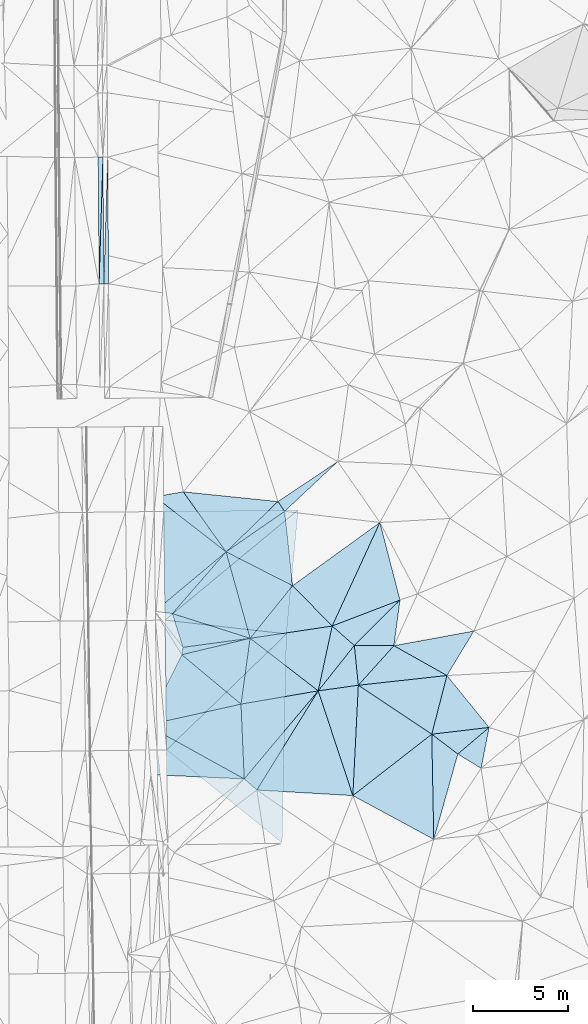
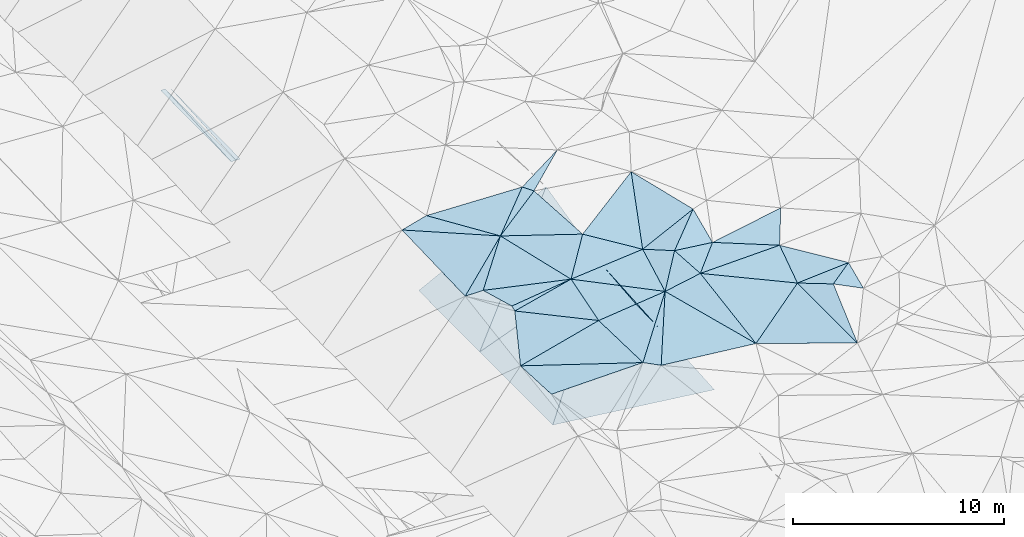
# One storey, part 38 of 275: 45 plates.
"""IFC2X3 building model written with IfcOpenShell, lengths in millimetres."""

import ifcopenshell
import ifcopenshell.guid

model = None  # the IFC model being written
_history = None  # IfcOwnerHistory: only IFC2X3 demands one
_inside = {}  # id of a spatial element -> (the spatial element, [elements in it])
_under = {}  # id of a project, library or spatial element -> (it, [spatial elements below it])
_declared = {}  # id of a project -> (the project, [libraries it declares])
_typed = {}  # id of a type object -> (the type object, [elements of that type])
_made_of = {}  # id of a material, layer set ... -> (it, [elements and type objects made of it])


def new_model(schema):
    """Start an empty IFC model of exactly this schema.

    Asked for "IFC4X3", IfcOpenShell would pick the latest addendum, in which some entities
    have other attributes; the version numbers below select the first issue.
    IFC2X3 requires an IfcOwnerHistory on every rooted entity: one is made here for all.
    """
    global model, _history
    if schema == "IFC4X3":
        model = ifcopenshell.file(schema_version=(4, 3, 0, 0))
    else:
        model = ifcopenshell.file(schema=schema)
    _inside.clear()
    _under.clear()
    _declared.clear()
    _typed.clear()
    _made_of.clear()
    _history = None
    if model.schema == "IFC2X3":
        org = make("IfcOrganization", Name="unknown")
        user = make(
            "IfcPersonAndOrganization",
            ThePerson=make("IfcPerson", FamilyName="unknown"),
            TheOrganization=org,
        )
        app = make(
            "IfcApplication",
            ApplicationDeveloper=org,
            Version="unknown",
            ApplicationFullName="unknown",
            ApplicationIdentifier="unknown",
        )
        _history = make(
            "IfcOwnerHistory",
            OwningUser=user,
            OwningApplication=app,
            ChangeAction="ADDED",
            CreationDate=0,
        )
    return model


def make(cls, **values):
    """One entity of the class cls with the attributes given. An attribute that is None is left unset."""
    return model.create_entity(
        cls, **{name: value for name, value in values.items() if value is not None}
    )


def rooted(cls, **values):
    """An entity with a GlobalId (a new one), such as an element, a storey or a relation."""
    return make(cls, GlobalId=ifcopenshell.guid.new(), OwnerHistory=_history, **values)


def si_unit(unit_type, name, prefix=None):
    """IfcSIUnit, for example si_unit("LENGTHUNIT", "METRE", prefix="MILLI")."""
    return make("IfcSIUnit", UnitType=unit_type, Prefix=prefix, Name=name)


def assignment(units):
    """IfcUnitAssignment: the units of a project."""
    return None if units is None else make("IfcUnitAssignment", Units=units)


def point(xyz):
    """IfcCartesianPoint."""
    return None if xyz is None else make("IfcCartesianPoint", Coordinates=xyz)


def direction(xyz):
    """IfcDirection."""
    return None if xyz is None else make("IfcDirection", DirectionRatios=xyz)


def frame(location, z_axis=None, x_axis=None):
    """IfcAxis2Placement3D, a coordinate frame: its origin and axes. An axis left out is left unset."""
    return make(
        "IfcAxis2Placement3D",
        Location=point(location),
        Axis=direction(z_axis),
        RefDirection=direction(x_axis),
    )


def origin_with_axes():
    """The frame at (0, 0, 0) with the z axis (0, 0, 1) and the x axis (1, 0, 0) written out."""
    return frame((0.0, 0.0, 0.0), z_axis=(0.0, 0.0, 1.0), x_axis=(1.0, 0.0, 0.0))


def place(relative_to, where):
    """IfcLocalPlacement: puts the frame where relative to a parent placement (None: the world)."""
    return make(
        "IfcLocalPlacement", PlacementRelTo=relative_to, RelativePlacement=where
    )


def context(
    kind, dimensions, precision=None, world=None, true_north=None, identifier=None
):
    """IfcGeometricRepresentationContext, for example the 3D "Model" context."""
    return make(
        "IfcGeometricRepresentationContext",
        ContextIdentifier=identifier,
        ContextType=kind,
        CoordinateSpaceDimension=dimensions,
        Precision=precision,
        WorldCoordinateSystem=world,
        TrueNorth=true_north,
    )


def subcontext(parent, identifier, kind, view, scale=None):
    """IfcGeometricRepresentationSubContext, for example "Body" below "Model"."""
    return make(
        "IfcGeometricRepresentationSubContext",
        ContextIdentifier=identifier,
        ContextType=kind,
        ParentContext=parent,
        TargetScale=scale,
        TargetView=view,
    )


def project(units=None, contexts=None):
    """IfcProject with its units and contexts."""
    return rooted(
        "IfcProject",
        Name="project",
        RepresentationContexts=contexts,
        UnitsInContext=assignment(units),
    )


def spatial(cls, under=None, at=None, **own):
    """A site, building, storey or space (cls), placed at a placement, below another one or the project."""
    s = rooted(cls, ObjectPlacement=at, **own)
    if under is not None:
        _under.setdefault(under.id(), (under, []))[1].append(s)
    return s


def polyline(points):
    """IfcPolyline through the points."""
    return make("IfcPolyline", Points=[point(p) for p in points])


def outline(outer, holes=None, kind="AREA"):
    """IfcArbitraryClosedProfileDef: a profile drawn as a closed curve; with holes, ...WithVoids."""
    if holes is None:
        return make("IfcArbitraryClosedProfileDef", ProfileType=kind, OuterCurve=outer)
    return make(
        "IfcArbitraryProfileDefWithVoids",
        ProfileType=kind,
        OuterCurve=outer,
        InnerCurves=holes,
    )


def extrude(swept, where, along, depth):
    """IfcExtrudedAreaSolid: the profile swept, set in the frame where, extruded along a direction by depth."""
    return make(
        "IfcExtrudedAreaSolid",
        SweptArea=swept,
        Position=where,
        ExtrudedDirection=direction(along),
        Depth=depth,
    )


def shape(context_of_items, identifier, shape_type, items):
    """IfcShapeRepresentation: the items that make up one representation, for example the "Body"."""
    return make(
        "IfcShapeRepresentation",
        ContextOfItems=context_of_items,
        RepresentationIdentifier=identifier,
        RepresentationType=shape_type,
        Items=items,
    )


def material(Name=None, Category=None):
    """IfcMaterial."""
    return make("IfcMaterial", Name=Name, Category=Category)


def made_of(thing, what):
    """Note that an element or type object is made of a material, layer set ...; save() writes the relation."""
    if what is not None:
        _made_of.setdefault(what.id(), (what, []))[1].append(thing)
    return thing


def type_object(cls, material=None, **own):
    """A type object (cls), such as IfcWallType, which elements share."""
    return made_of(rooted(cls, **own), material)


def element(
    cls,
    number,
    at=None,
    inside=None,
    cuts=None,
    type_object=None,
    material=None,
    context=None,
    identifier="Body",
    shape_type=None,
    held_by="IfcProductDefinitionShape",
    body=None,
    shapes=None,
    **own,
):
    """One element of the class cls, such as IfcWall. Its Tag is "e" and its number.

    at: its placement. inside: the storey or other place that contains it. cuts: it is an
    opening in that element (IfcRelVoidsElement). A single representation is given by context,
    identifier, shape_type and body (its items); several are given by shapes. held_by: the class
    of the entity that holds the representations. save() writes the other relations.
    """
    e = rooted(cls, Tag="e%d" % number, ObjectPlacement=at, **own)
    if body is not None:
        shapes = [shape(context, identifier, shape_type, body)]
    if shapes is not None:
        e.Representation = make(held_by, Representations=shapes)
    if inside is not None:
        _inside.setdefault(inside.id(), (inside, []))[1].append(e)
    if cuts is not None:
        rooted(
            "IfcRelVoidsElement", RelatingBuildingElement=cuts, RelatedOpeningElement=e
        )
    if type_object is not None:
        _typed.setdefault(type_object.id(), (type_object, []))[1].append(e)
    return made_of(e, material)


def aggregate(whole, parts):
    """IfcRelAggregates: a whole, such as a stair, and the parts it consists of."""
    return rooted("IfcRelAggregates", RelatingObject=whole, RelatedObjects=parts)


def save(model, path):
    """Write the relations noted so far, then the file.

    IfcRelAggregates (storeys below a building ...), IfcRelContainedInSpatialStructure (elements
    in a storey), IfcRelDefinesByType, IfcRelAssociatesMaterial and IfcRelDeclares: one each for
    every whole, place, type object, material and project.
    """
    for whole, parts in _under.values():
        aggregate(whole, parts)
    for where, things in _inside.values():
        rooted(
            "IfcRelContainedInSpatialStructure",
            RelatedElements=things,
            RelatingStructure=where,
        )
    for kind, things in _typed.values():
        rooted("IfcRelDefinesByType", RelatedObjects=things, RelatingType=kind)
    for what, things in _made_of.values():
        rooted("IfcRelAssociatesMaterial", RelatedObjects=things, RelatingMaterial=what)
    for by, libraries in _declared.values():
        rooted("IfcRelDeclares", RelatingContext=by, RelatedDefinitions=libraries)
    model.write(path)


model = new_model("IFC2X3")

# Units and contexts
model_context = context("Model", 3, precision=1e-05, world=origin_with_axes())
body_context = subcontext(model_context, "Body", "Model", "MODEL_VIEW")
ifc_project = project(units=[si_unit("LENGTHUNIT", "METRE", prefix="MILLI"), si_unit("AREAUNIT", "SQUARE_METRE"), si_unit("VOLUMEUNIT", "CUBIC_METRE"), si_unit("MASSUNIT", "GRAM", prefix="KILO"), si_unit("TIMEUNIT", "SECOND"), si_unit("PLANEANGLEUNIT", "RADIAN"), si_unit("SOLIDANGLEUNIT", "STERADIAN"), si_unit("THERMODYNAMICTEMPERATUREUNIT", "DEGREE_CELSIUS"), si_unit("LUMINOUSINTENSITYUNIT", "LUMEN")], contexts=[model_context])

# Site, building, storey
site_placement = place(None, origin_with_axes())
site = spatial("IfcSite", under=ifc_project, at=site_placement, CompositionType="ELEMENT")
building_placement = place(site_placement, origin_with_axes())
building = spatial("IfcBuilding", under=site, at=building_placement, Name="Undefined", CompositionType="ELEMENT")
storey_placement = place(building_placement, origin_with_axes())
storey = spatial("IfcBuildingStorey", under=building, at=storey_placement, Name="Undefined", CompositionType="ELEMENT", Elevation=0.0)

# Plates
ifc_material = material()
plate_type_1 = type_object("IfcPlateType", PredefinedType="NOTDEFINED")
plate_1_placement = place(storey_placement, frame((-54942.9915111261, 36382.3782715387, 42080.1552035688), z_axis=(0.0198445312572419, 0.0205778341009198, -0.999591290139573), x_axis=(0.0071782370249891, -0.999765334401105, -0.0204389100262064)))
element("IfcPlate", 1, at=plate_1_placement, inside=storey, type_object=plate_type_1, material=ifc_material, Name="00_PR", context=body_context, shape_type="SweptSolid", body=[
    extrude(outline(polyline([(0.0, 0.0), (6633.6708984375, -2.11002770811319e-10), (6633.7734375, 250.050033569336), (0.0, 0.0)])), frame((-8.85201319254618e-08, 2.18876761149539e-07, -0.5000001331573), z_axis=(0.0, 0.0, 1.0), x_axis=(1.0, 0.0, 0.0)), (0.0, 0.0, 1.0), 1.0),
])
plate_2_placement = place(storey_placement, frame((-54693.0324596577, 36384.1727438642, 42067.6557273088), z_axis=(-0.0500723807362352, 0.0200544303251957, -0.998544228620714), x_axis=(0.0071782370249891, -0.999765334401105, -0.0204389100262064)))
element("IfcPlate", 2, at=plate_2_placement, inside=storey, type_object=plate_type_1, material=ifc_material, Name="00_PR", context=body_context, shape_type="SweptSolid", body=[
    extrude(outline(polyline([(0.0, 0.0), (6633.6708984375, -2.11002770811319e-10), (6633.4150390625, 250.311706542969), (0.0, 0.0)])), frame((-8.85201319254618e-08, 2.18876761149539e-07, -0.5000001331573), z_axis=(0.0, 0.0, 1.0), x_axis=(1.0, 0.0, 0.0)), (0.0, 0.0, 1.0), 1.0),
])
plate_3_placement = place(storey_placement, frame((-55145.3670530772, 29748.4686331468, 41939.5702051205), z_axis=(0.0198445312572419, 0.0205778341009198, -0.999591290139573), x_axis=(-0.00717823700979567, 0.999765334400991, 0.0204389100371159)))
element("IfcPlate", 3, at=plate_3_placement, inside=storey, type_object=plate_type_1, material=ifc_material, Name="00_PR", context=body_context, shape_type="SweptSolid", body=[
    extrude(outline(polyline([(0.0, 0.0), (6633.671875, 2.05327523872256e-08), (6633.7734375, 250.049514770508), (0.0, 0.0)])), frame((-8.85201319254618e-08, 2.18876761149539e-07, -0.5000001331573), z_axis=(0.0, 0.0, 1.0), x_axis=(1.0, 0.0, 0.0)), (0.0, 0.0, 1.0), 1.0),
])
plate_type_2 = type_object("IfcPlateType", PredefinedType="NOTDEFINED")
plate_4_placement = place(storey_placement, frame((-45430.231883787, 17833.4559001937, 44079.5016784651), z_axis=(0.0278588885497635, 0.0772522264791411, -0.996622283431786), x_axis=(0.106934338629131, -0.991518355710877, -0.0738674320005101)))
element("IfcPlate", 4, at=plate_4_placement, inside=storey, type_object=plate_type_2, material=ifc_material, Name="00", context=body_context, shape_type="SweptSolid", body=[
    extrude(outline(polyline([(0.0, 0.0), (3925.9521484375, 1.47701939567924e-09), (1792.91540527344, 3276.21044921875), (0.0, 0.0)])), frame((-8.85201319254618e-08, 2.18876761149539e-07, -0.5000001331573), z_axis=(0.0, 0.0, 1.0), x_axis=(1.0, 0.0, 0.0)), (0.0, 0.0, 1.0), 1.0),
])
plate_type_3 = type_object("IfcPlateType", PredefinedType="NOTDEFINED")
plate_5_placement = place(storey_placement, frame((-39706.3607982611, 10796.9886034841, 43359.5010595208), z_axis=(-0.0651260608262008, 0.00556111429460332, -0.997861548617374), x_axis=(0.870385619377066, -0.488758669464644, -0.0595301319060548)))
element("IfcPlate", 5, at=plate_5_placement, inside=storey, type_object=plate_type_3, material=ifc_material, Name="00", context=body_context, shape_type="SweptSolid", body=[
    extrude(outline(polyline([(0.0, 0.0), (3191.66088867188, 9.51149559114128e-09), (-615.760864257813, 2717.37719726563), (0.0, 0.0)])), frame((-8.85201319254618e-08, 2.18876761149539e-07, -0.5000001331573), z_axis=(0.0, 0.0, 1.0), x_axis=(1.0, 0.0, 0.0)), (0.0, 0.0, 1.0), 1.0),
])
plate_type_4 = type_object("IfcPlateType", PredefinedType="NOTDEFINED")
plate_6_placement = place(storey_placement, frame((-44724.4771058375, 17903.7667722311, 44038.7318903429), z_axis=(0.446903759838823, 0.0251629956808119, -0.894228076661816), x_axis=(-0.0919898739759389, -0.993012730312049, -0.0739160369886005)))
element("IfcPlate", 6, at=plate_6_placement, inside=storey, type_object=plate_type_4, material=ifc_material, Name="00_PR", context=body_context, shape_type="SweptSolid", body=[
    extrude(outline(polyline([(0.0, 0.0), (6534.427734375, -7.82165443524718e-09), (6635.34326171875, 7143.662109375), (0.0, 0.0)])), frame((-8.85201319254618e-08, 2.18876761149539e-07, -0.5000001331573), z_axis=(0.0, 0.0, 1.0), x_axis=(1.0, 0.0, 0.0)), (0.0, 0.0, 1.0), 1.0),
])
plate_type_5 = type_object("IfcPlateType", PredefinedType="NOTDEFINED")
plate_7_placement = place(storey_placement, frame((-45325.5784005657, 11414.9969817729, 43555.7328380618), z_axis=(0.446680012940053, 0.0253921294447093, -0.89433338627278), x_axis=(-0.0212792639438346, -0.999012910810186, -0.0389922679587617)))
element("IfcPlate", 7, at=plate_7_placement, inside=storey, type_object=plate_type_5, material=ifc_material, Name="00_PR", context=body_context, shape_type="SweptSolid", body=[
    extrude(outline(polyline([(0.0, 0.0), (10952.9150390625, -5.12955011799932e-09), (6325.18896484375, 6871.359375), (0.0, 0.0)])), frame((-8.85201319254618e-08, 2.18876761149539e-07, -0.5000001331573), z_axis=(0.0, 0.0, 1.0), x_axis=(1.0, 0.0, 0.0)), (0.0, 0.0, 1.0), 1.0),
])
plate_type_6 = type_object("IfcPlateType", PredefinedType="NOTDEFINED")
plate_8_placement = place(storey_placement, frame((-51691.5765874755, 12138.4029524377, 40394.586883327), z_axis=(0.446872865494103, 0.0252092656988721, -0.894242212718687), x_axis=(-0.0115226870499545, 0.999682155734166, 0.022423540974605)))
element("IfcPlate", 8, at=plate_8_placement, inside=storey, type_object=plate_type_6, material=ifc_material, Name="00_PR", context=body_context, shape_type="SweptSolid", body=[
    extrude(outline(polyline([(0.0, 0.0), (5690.53759765625, -5.3114490583539e-10), (5764.96630859375, 7862.8779296875), (0.0, 0.0)])), frame((-8.85201319254618e-08, 2.18876761149539e-07, -0.5000001331573), z_axis=(0.0, 0.0, 1.0), x_axis=(1.0, 0.0, 0.0)), (0.0, 0.0, 1.0), 1.0),
])
plate_type_7 = type_object("IfcPlateType", PredefinedType="NOTDEFINED")
plate_9_placement = place(storey_placement, frame((-51606.1972889804, 5346.4973654503, 40246.5428887471), z_axis=(0.446899491070269, 0.0251095362468801, -0.894231712740384), x_axis=(-0.0125667630554567, 0.999683581198485, 0.0217902259850709)))
element("IfcPlate", 9, at=plate_9_placement, inside=storey, type_object=plate_type_7, material=ifc_material, Name="00_PR", context=body_context, shape_type="SweptSolid", body=[
    extrude(outline(polyline([(0.0, 0.0), (6794.05517578125, -5.5297277867794e-09), (6059.76025390625, 7106.53955078125), (0.0, 0.0)])), frame((-8.85201319254618e-08, 2.18876761149539e-07, -0.5000001331573), z_axis=(0.0, 0.0, 1.0), x_axis=(1.0, 0.0, 0.0)), (0.0, 0.0, 1.0), 1.0),
])
plate_type_8 = type_object("IfcPlateType", PredefinedType="NOTDEFINED")
plate_10_placement = place(storey_placement, frame((-41855.9755057168, 2947.52692122357, 43009.5021130421), z_axis=(0.050879424054759, 0.0767183679161113, -0.995753772893753), x_axis=(-0.313273531606973, 0.947949097745862, 0.0570280849871394)))
element("IfcPlate", 10, at=plate_10_placement, inside=storey, type_object=plate_type_8, material=ifc_material, Name="00", context=body_context, shape_type="SweptSolid", body=[
    extrude(outline(polyline([(0.0, 0.0), (5786.62255859375, 4.63478500023484e-09), (5415.1279296875, 2092.10229492188), (0.0, 0.0)])), frame((-8.85201319254618e-08, 2.18876761149539e-07, -0.5000001331573), z_axis=(0.0, 0.0, 1.0), x_axis=(1.0, 0.0, 0.0)), (0.0, 0.0, 1.0), 1.0),
])
plate_type_9 = type_object("IfcPlateType", PredefinedType="NOTDEFINED")
plate_11_placement = place(storey_placement, frame((-48494.6611058012, 15713.3185352938, 43829.5005989199), z_axis=(0.0127846669744032, 0.0476697506053442, -0.998781331006731), x_axis=(0.89124718195064, -0.453402439250082, -0.0102317519085897)))
element("IfcPlate", 11, at=plate_11_placement, inside=storey, type_object=plate_type_9, material=ifc_material, Name="00", context=body_context, shape_type="SweptSolid", body=[
    extrude(outline(polyline([(0.0, 0.0), (3909.39892578125, 3.64889274351299e-09), (3176.421875, 3469.18505859375), (0.0, 0.0)])), frame((-8.85201319254618e-08, 2.18876761149539e-07, -0.5000001331573), z_axis=(0.0, 0.0, 1.0), x_axis=(1.0, 0.0, 0.0)), (0.0, 0.0, 1.0), 1.0),
])
plate_type_10 = type_object("IfcPlateType", PredefinedType="NOTDEFINED")
plate_12_placement = place(storey_placement, frame((-36357.6802074656, 5126.7429942699, 43219.5032496987), z_axis=(-0.0131080272075688, -0.11314237284293, -0.993492316573308), x_axis=(-0.79525424323636, 0.603472943562298, -0.0582331091632559)))
element("IfcPlate", 12, at=plate_12_placement, inside=storey, type_object=plate_type_10, material=ifc_material, Name="00", context=body_context, shape_type="SweptSolid", body=[
    extrude(outline(polyline([(0.0, 0.0), (1717.23620605469, -4.3473846744746e-09), (-452.354797363281, 2107.95532226563), (0.0, 0.0)])), frame((-8.85201319254618e-08, 2.18876761149539e-07, -0.5000001331573), z_axis=(0.0, 0.0, 1.0), x_axis=(1.0, 0.0, 0.0)), (0.0, 0.0, 1.0), 1.0),
])
plate_type_11 = type_object("IfcPlateType", PredefinedType="NOTDEFINED")
plate_13_placement = place(storey_placement, frame((-45430.2877897706, 17833.4276903817, 44079.5018639715), z_axis=(-0.0839553284117798, 0.0208324255081803, -0.996251731681665), x_axis=(-0.559073778349548, 0.826613140354134, 0.0643989639345107)))
element("IfcPlate", 13, at=plate_13_placement, inside=storey, type_object=plate_type_11, material=ifc_material, Name="00", context=body_context, shape_type="SweptSolid", body=[
    extrude(outline(polyline([(0.0, 0.0), (621.127990722656, 8.94942786544561e-10), (588.284545898438, 3772.78686523438), (0.0, 0.0)])), frame((-8.85201319254618e-08, 2.18876761149539e-07, -0.5000001331573), z_axis=(0.0, 0.0, 1.0), x_axis=(1.0, 0.0, 0.0)), (0.0, 0.0, 1.0), 1.0),
])
plate_type_12 = type_object("IfcPlateType", PredefinedType="NOTDEFINED")
plate_14_placement = place(storey_placement, frame((-48494.620250239, 15713.2859201061, 43829.5023044076), z_axis=(0.0945006643430006, -0.0175605628910045, -0.995369906652639), x_axis=(-0.655536350395598, -0.753575990297132, -0.0489420081087571)))
element("IfcPlate", 14, at=plate_14_placement, inside=storey, type_object=plate_type_12, material=ifc_material, Name="00", context=body_context, shape_type="SweptSolid", body=[
    extrude(outline(polyline([(0.0, 0.0), (4290.79248046875, 2.91038304567337e-09), (4805.4365234375, 771.37841796875), (0.0, 0.0)])), frame((-8.85201319254618e-08, 2.18876761149539e-07, -0.5000001331573), z_axis=(0.0, 0.0, 1.0), x_axis=(1.0, 0.0, 0.0)), (0.0, 0.0, 1.0), 1.0),
])
plate_type_13 = type_object("IfcPlateType", PredefinedType="NOTDEFINED")
plate_15_placement = place(storey_placement, frame((-45777.4928044261, 18346.8949830635, 44119.5021204198), z_axis=(0.018777146590365, 0.0902749081640818, -0.995739855445131), x_axis=(0.559073778349328, -0.826613140354061, -0.0643989639373485)))
element("IfcPlate", 15, at=plate_15_placement, inside=storey, type_object=plate_type_13, material=ifc_material, Name="00", context=body_context, shape_type="SweptSolid", body=[
    extrude(outline(polyline([(0.0, 0.0), (621.127990722656, 8.94942786544561e-10), (676.511108398438, 3734.30493164063), (0.0, 0.0)])), frame((-8.85201319254618e-08, 2.18876761149539e-07, -0.5000001331573), z_axis=(0.0, 0.0, 1.0), x_axis=(1.0, 0.0, 0.0)), (0.0, 0.0, 1.0), 1.0),
])
plate_type_14 = type_object("IfcPlateType", PredefinedType="NOTDEFINED")
plate_16_placement = place(storey_placement, frame((-50814.1468648743, 10325.373270095, 43559.5014812479), z_axis=(0.000948842049907377, 0.0771976103223906, -0.997015360292547), x_axis=(0.149462099418987, 0.985805826546631, 0.0764719110783946)))
element("IfcPlate", 16, at=plate_16_placement, inside=storey, type_object=plate_type_14, material=ifc_material, Name="00", context=body_context, shape_type="SweptSolid", body=[
    extrude(outline(polyline([(0.0, 0.0), (392.300903320313, -2.7648638933897e-10), (1387.96520996094, 3408.58520507813), (0.0, 0.0)])), frame((-8.85201319254618e-08, 2.18876761149539e-07, -0.5000001331573), z_axis=(0.0, 0.0, 1.0), x_axis=(1.0, 0.0, 0.0)), (0.0, 0.0, 1.0), 1.0),
])
plate_type_15 = type_object("IfcPlateType", PredefinedType="NOTDEFINED")
plate_17_placement = place(storey_placement, frame((-36928.3671123914, 9237.0457684159, 43169.5003498522), z_axis=(-0.0294380107991714, 0.0238672213899403, -0.999281621597891), x_axis=(0.62992284668512, -0.775771775810762, -0.0370858339468355)))
element("IfcPlate", 17, at=plate_17_placement, inside=storey, type_object=plate_type_15, material=ifc_material, Name="00", context=body_context, shape_type="SweptSolid", body=[
    extrude(outline(polyline([(0.0, 0.0), (3505.38159179688, -8.88758222572505e-09), (1885.75756835938, 2554.88134765625), (0.0, 0.0)])), frame((-8.85201319254618e-08, 2.18876761149539e-07, -0.5000001331573), z_axis=(0.0, 0.0, 1.0), x_axis=(1.0, 0.0, 0.0)), (0.0, 0.0, 1.0), 1.0),
])
plate_type_16 = type_object("IfcPlateType", PredefinedType="NOTDEFINED")
plate_18_placement = place(storey_placement, frame((-35139.7908724898, 4375.10524067257, 42999.5061473139), z_axis=(-0.149018602807962, 0.0476148267760239, -0.987687341362767), x_axis=(-0.841091380695476, 0.519118095658402, 0.15192660096169)))
element("IfcPlate", 18, at=plate_18_placement, inside=storey, type_object=plate_type_16, material=ifc_material, Name="00", context=body_context, shape_type="SweptSolid", body=[
    extrude(outline(polyline([(0.0, 0.0), (1448.06762695313, -3.21779225487262e-09), (765.502868652344, 2045.04406738281), (0.0, 0.0)])), frame((-8.85201319254618e-08, 2.18876761149539e-07, -0.5000001331573), z_axis=(0.0, 0.0, 1.0), x_axis=(1.0, 0.0, 0.0)), (0.0, 0.0, 1.0), 1.0),
])
plate_type_17 = type_object("IfcPlateType", PredefinedType="NOTDEFINED")
plate_19_placement = place(storey_placement, frame((-43668.8156130637, 8432.92486485078, 43339.5005128098), z_axis=(-0.0379955658647295, 0.0254427336003647, -0.998953955035746), x_axis=(-0.526323498276441, -0.850282832061693, -0.00163727309747071)))
element("IfcPlate", 19, at=plate_19_placement, inside=storey, type_object=plate_type_17, material=ifc_material, Name="00", context=body_context, shape_type="SweptSolid", body=[
    extrude(outline(polyline([(0.0, 0.0), (6107.71630859375, 8.45466274768114e-09), (5961.08203125, 870.056579589844), (0.0, 0.0)])), frame((-8.85201319254618e-08, 2.18876761149539e-07, -0.5000001331573), z_axis=(0.0, 0.0, 1.0), x_axis=(1.0, 0.0, 0.0)), (0.0, 0.0, 1.0), 1.0),
])
plate_type_18 = type_object("IfcPlateType", PredefinedType="NOTDEFINED")
plate_20_placement = place(storey_placement, frame((-39386.9272178726, 13190.6327187231, 43729.5101773593), z_axis=(-0.112393175132513, 0.166432423892355, -0.979626470886198), x_axis=(-0.130765943420732, -0.979776323612556, -0.151455022133798)))
element("IfcPlate", 20, at=plate_20_placement, inside=storey, type_object=plate_type_18, material=ifc_material, Name="00", context=body_context, shape_type="SweptSolid", body=[
    extrude(outline(polyline([(0.0, 0.0), (2442.96948242188, 1.58615875989199e-09), (2664.6669921875, 2074.37939453125), (0.0, 0.0)])), frame((-8.85201319254618e-08, 2.18876761149539e-07, -0.5000001331573), z_axis=(0.0, 0.0, 1.0), x_axis=(1.0, 0.0, 0.0)), (0.0, 0.0, 1.0), 1.0),
])
plate_type_19 = type_object("IfcPlateType", PredefinedType="NOTDEFINED")
plate_21_placement = place(storey_placement, frame((-48494.6213731112, 15713.3370859877, 43829.5039290652), z_axis=(0.0922507108258516, 0.0847710672764678, -0.992120795319266), x_axis=(-0.790471279683835, 0.612132194716388, -0.021197457080911)))
element("IfcPlate", 21, at=plate_21_placement, inside=storey, type_object=plate_type_19, material=ifc_material, Name="00", context=body_context, shape_type="SweptSolid", body=[
    extrude(outline(polyline([(0.0, 0.0), (4717.546875, 9.27320797927678e-09), (3694.03002929688, 1120.06372070313), (0.0, 0.0)])), frame((-8.85201319254618e-08, 2.18876761149539e-07, -0.5000001331573), z_axis=(0.0, 0.0, 1.0), x_axis=(1.0, 0.0, 0.0)), (0.0, 0.0, 1.0), 1.0),
])
plate_type_20 = type_object("IfcPlateType", PredefinedType="NOTDEFINED")
plate_22_placement = place(storey_placement, frame((-42939.1427185893, 11827.8251354909, 43469.5037350002), z_axis=(0.121587340745411, 0.0118757228416838, -0.992509690520675), x_axis=(0.74924204674187, -0.656957325805214, 0.0839251301155748)))
element("IfcPlate", 22, at=plate_22_placement, inside=storey, type_object=plate_type_20, material=ifc_material, Name="00", context=body_context, shape_type="SweptSolid", body=[
    extrude(outline(polyline([(0.0, 0.0), (1548.99963378906, -2.72302713710815e-09), (1672.75695800781, 3045.73217773438), (0.0, 0.0)])), frame((-8.85201319254618e-08, 2.18876761149539e-07, -0.5000001331573), z_axis=(0.0, 0.0, 1.0), x_axis=(1.0, 0.0, 0.0)), (0.0, 0.0, 1.0), 1.0),
])
plate_type_21 = type_object("IfcPlateType", PredefinedType="NOTDEFINED")
plate_23_placement = place(storey_placement, frame((-41568.5360125432, 8727.32610794116, 43469.5039217996), z_axis=(-0.114581709718138, 0.0503619554656153, -0.992136434790976), x_axis=(-0.100190346651086, 0.993036025941507, 0.0619785900148976)))
element("IfcPlate", 23, at=plate_23_placement, inside=storey, type_object=plate_type_21, material=ifc_material, Name="00", context=body_context, shape_type="SweptSolid", body=[
    extrude(outline(polyline([(0.0, 0.0), (2097.49853515625, 9.53150447458029e-10), (1861.88452148438, 2072.84497070313), (0.0, 0.0)])), frame((-8.85201319254618e-08, 2.18876761149539e-07, -0.5000001331573), z_axis=(0.0, 0.0, 1.0), x_axis=(1.0, 0.0, 0.0)), (0.0, 0.0, 1.0), 1.0),
])
plate_type_22 = type_object("IfcPlateType", PredefinedType="NOTDEFINED")
plate_24_placement = place(storey_placement, frame((-50755.5088645223, 10712.0770325479, 43589.5001048211), z_axis=(0.00871572724061841, 0.0196875672467047, -0.999768191029587), x_axis=(-0.297985271606881, 0.954433042764531, 0.0161970609868876)))
element("IfcPlate", 24, at=plate_24_placement, inside=storey, type_object=plate_type_22, material=ifc_material, Name="00", context=body_context, shape_type="SweptSolid", body=[
    extrude(outline(polyline([(0.0, 0.0), (1852.18786621094, -1.20053300634027e-09), (-596.213806152344, 3500.61840820313), (0.0, 0.0)])), frame((-8.85201319254618e-08, 2.18876761149539e-07, -0.5000001331573), z_axis=(0.0, 0.0, 1.0), x_axis=(1.0, 0.0, 0.0)), (0.0, 0.0, 1.0), 1.0),
])
plate_type_23 = type_object("IfcPlateType", PredefinedType="NOTDEFINED")
plate_25_placement = place(storey_placement, frame((-41778.5854939046, 10810.1771738899, 43599.5020215547), z_axis=(0.0846614664789734, -0.0306751317412602, -0.995937484175732), x_axis=(-0.749242046741505, 0.656957325806155, -0.0839251301114647)))
element("IfcPlate", 25, at=plate_25_placement, inside=storey, type_object=plate_type_23, material=ifc_material, Name="00", context=body_context, shape_type="SweptSolid", body=[
    extrude(outline(polyline([(0.0, 0.0), (1548.99963378906, -2.72302713710815e-09), (-239.1220703125, 3368.42993164063), (0.0, 0.0)])), frame((-8.85201319254618e-08, 2.18876761149539e-07, -0.5000001331573), z_axis=(0.0, 0.0, 1.0), x_axis=(1.0, 0.0, 0.0)), (0.0, 0.0, 1.0), 1.0),
])
plate_type_24 = type_object("IfcPlateType", PredefinedType="NOTDEFINED")
plate_26_placement = place(storey_placement, frame((-41778.6017173751, 10810.2262386502, 43599.5018126389), z_axis=(0.0522151906133822, 0.0674538913550723, -0.996355130668913), x_axis=(0.100190346652764, -0.993036025941059, -0.0619785900193516)))
element("IfcPlate", 26, at=plate_26_placement, inside=storey, type_object=plate_type_24, material=ifc_material, Name="00", context=body_context, shape_type="SweptSolid", body=[
    extrude(outline(polyline([(0.0, 0.0), (2097.49853515625, 9.53150447458029e-10), (2187.462890625, 2122.92407226563), (0.0, 0.0)])), frame((-8.85201319254618e-08, 2.18876761149539e-07, -0.5000001331573), z_axis=(0.0, 0.0, 1.0), x_axis=(1.0, 0.0, 0.0)), (0.0, 0.0, 1.0), 1.0),
])
plate_type_25 = type_object("IfcPlateType", PredefinedType="NOTDEFINED")
plate_27_placement = place(storey_placement, frame((-40438.8904320849, 17251.9932106399, 43799.5011744957), z_axis=(0.0604182480259943, 0.0328449264089425, -0.997632620815228), x_axis=(0.250723345741126, -0.967915029276486, -0.0166823260091487)))
element("IfcPlate", 27, at=plate_27_placement, inside=storey, type_object=plate_type_25, material=ifc_material, Name="00", context=body_context, shape_type="SweptSolid", body=[
    extrude(outline(polyline([(0.0, 0.0), (4196.0576171875, -1.99725036509335e-09), (4628.74951171875, 3788.99438476563), (0.0, 0.0)])), frame((-8.85201319254618e-08, 2.18876761149539e-07, -0.5000001331573), z_axis=(0.0, 0.0, 1.0), x_axis=(1.0, 0.0, 0.0)), (0.0, 0.0, 1.0), 1.0),
])
plate_type_26 = type_object("IfcPlateType", PredefinedType="NOTDEFINED")
plate_28_placement = place(storey_placement, frame((-45010.4526635237, 13940.8135009285, 43789.5031540357), z_axis=(-0.0518908237966247, 0.0996227481899733, -0.993671298996195), x_axis=(0.695962810178708, -0.709981802249357, -0.107524914893761)))
element("IfcPlate", 28, at=plate_28_placement, inside=storey, type_object=plate_type_26, material=ifc_material, Name="00", context=body_context, shape_type="SweptSolid", body=[
    extrude(outline(polyline([(0.0, 0.0), (2976.05444335938, -6.63203536532819e-09), (424.252990722656, 3520.29956054688), (0.0, 0.0)])), frame((-8.85201319254618e-08, 2.18876761149539e-07, -0.5000001331573), z_axis=(0.0, 0.0, 1.0), x_axis=(1.0, 0.0, 0.0)), (0.0, 0.0, 1.0), 1.0),
])
plate_type_27 = type_object("IfcPlateType", PredefinedType="NOTDEFINED")
plate_29_placement = place(storey_placement, frame((-36928.3545010049, 9237.09058106658, 43169.5032258447), z_axis=(-0.00422152770822132, 0.113492832490335, -0.993529846394727), x_axis=(-0.870385619376956, 0.488758669464559, 0.0595301319083668)))
element("IfcPlate", 29, at=plate_29_placement, inside=storey, type_object=plate_type_27, material=ifc_material, Name="00", context=body_context, shape_type="SweptSolid", body=[
    extrude(outline(polyline([(0.0, 0.0), (3191.66088867188, 9.51149559114128e-09), (-72.658088684082, 2732.91430664063), (0.0, 0.0)])), frame((-8.85201319254618e-08, 2.18876761149539e-07, -0.5000001331573), z_axis=(0.0, 0.0, 1.0), x_axis=(1.0, 0.0, 0.0)), (0.0, 0.0, 1.0), 1.0),
])
plate_type_28 = type_object("IfcPlateType", PredefinedType="NOTDEFINED")
plate_30_placement = place(storey_placement, frame((-42939.2347602222, 11827.8638397122, 43469.5029680587), z_axis=(-0.0624953551355466, 0.0892839949510513, -0.994043610125865), x_axis=(-0.695962809665069, 0.709981802743233, 0.107524914957285)))
element("IfcPlate", 30, at=plate_30_placement, inside=storey, type_object=plate_type_28, material=ifc_material, Name="00", context=body_context, shape_type="SweptSolid", body=[
    extrude(outline(polyline([(0.0, 0.0), (2976.05444335938, -6.63203536532819e-09), (2146.4326171875, 5583.42431640625), (0.0, 0.0)])), frame((-8.85201319254618e-08, 2.18876761149539e-07, -0.5000001331573), z_axis=(0.0, 0.0, 1.0), x_axis=(1.0, 0.0, 0.0)), (0.0, 0.0, 1.0), 1.0),
])
plate_type_29 = type_object("IfcPlateType", PredefinedType="NOTDEFINED")
plate_31_placement = place(storey_placement, frame((-47236.4251668296, 11185.4411421809, 43629.5010439531), z_axis=(-0.0450404889197343, 0.046757930579533, -0.997890299725271), x_axis=(0.790109797365441, -0.60959131645783, -0.0642256569164743)))
element("IfcPlate", 31, at=plate_31_placement, inside=storey, type_object=plate_type_29, material=ifc_material, Name="00", context=body_context, shape_type="SweptSolid", body=[
    extrude(outline(polyline([(0.0, 0.0), (4515.32958984375, -3.09228198602796e-09), (1733.58337402344, 3020.7265625), (0.0, 0.0)])), frame((-8.85201319254618e-08, 2.18876761149539e-07, -0.5000001331573), z_axis=(0.0, 0.0, 1.0), x_axis=(1.0, 0.0, 0.0)), (0.0, 0.0, 1.0), 1.0),
])
plate_type_30 = type_object("IfcPlateType", PredefinedType="NOTDEFINED")
plate_32_placement = place(storey_placement, frame((-48494.6415007342, 15713.3227726147, 43829.5014554311), z_axis=(0.0519990681489821, 0.0561444692962946, -0.997067648396574), x_axis=(-0.580764817770726, 0.813922982962115, 0.0155436239593139)))
element("IfcPlate", 32, at=plate_32_placement, inside=storey, type_object=plate_type_30, material=ifc_material, Name="00", context=body_context, shape_type="SweptSolid", body=[
    extrude(outline(polyline([(0.0, 0.0), (3860.103515625, -6.02449290454388e-09), (569.984680175781, 3752.04174804688), (0.0, 0.0)])), frame((-8.85201319254618e-08, 2.18876761149539e-07, -0.5000001331573), z_axis=(0.0, 0.0, 1.0), x_axis=(1.0, 0.0, 0.0)), (0.0, 0.0, 1.0), 1.0),
])
plate_type_31 = type_object("IfcPlateType", PredefinedType="NOTDEFINED")
plate_33_placement = place(storey_placement, frame((-52222.7173674253, 12598.9427990879, 43530.500950059), z_axis=(0.0523969233672968, 0.0330999677601377, -0.998077629523836), x_axis=(-0.000168076651777105, 0.999450815158434, 0.0331366840432272)))
element("IfcPlate", 33, at=plate_33_placement, inside=storey, type_object=plate_type_31, material=ifc_material, Name="00", context=body_context, shape_type="SweptSolid", body=[
    extrude(outline(polyline([(0.0, 0.0), (6005.42919921875, -3.8635334931314e-09), (3121.939453125, 3733.72973632813), (0.0, 0.0)])), frame((-8.85201319254618e-08, 2.18876761149539e-07, -0.5000001331573), z_axis=(0.0, 0.0, 1.0), x_axis=(1.0, 0.0, 0.0)), (0.0, 0.0, 1.0), 1.0),
])
plate_type_32 = type_object("IfcPlateType", PredefinedType="NOTDEFINED")
plate_34_placement = place(storey_placement, frame((-43668.8187582154, 8432.93600790082, 43339.5010509939), z_axis=(-0.0442897892520754, 0.0477296284433492, -0.997877896907566), x_axis=(-0.790109797365909, 0.609591316457557, 0.0642256569132968)))
element("IfcPlate", 34, at=plate_34_placement, inside=storey, type_object=plate_type_32, material=ifc_material, Name="00", context=body_context, shape_type="SweptSolid", body=[
    extrude(outline(polyline([(0.0, 0.0), (4515.32958984375, -3.09228198602796e-09), (1501.396484375, 3133.75317382813), (0.0, 0.0)])), frame((-8.85201319254618e-08, 2.18876761149539e-07, -0.5000001331573), z_axis=(0.0, 0.0, 1.0), x_axis=(1.0, 0.0, 0.0)), (0.0, 0.0, 1.0), 1.0),
])
plate_type_33 = type_object("IfcPlateType", PredefinedType="NOTDEFINED")
plate_35_placement = place(storey_placement, frame((-41568.497015076, 8727.34147255737, 43469.5019727238), z_axis=(-0.036585435001342, 0.0810917683280845, -0.996034954735619), x_axis=(0.829599755476566, -0.553228737530925, -0.0755129769189453)))
element("IfcPlate", 35, at=plate_35_placement, inside=storey, type_object=plate_type_33, material=ifc_material, Name="00", context=body_context, shape_type="SweptSolid", body=[
    extrude(outline(polyline([(0.0, 0.0), (4634.96484375, -6.53017195872962e-09), (2993.76586914063, 4973.71728515625), (0.0, 0.0)])), frame((-8.85201319254618e-08, 2.18876761149539e-07, -0.5000001331573), z_axis=(0.0, 0.0, 1.0), x_axis=(1.0, 0.0, 0.0)), (0.0, 0.0, 1.0), 1.0),
])
plate_type_34 = type_object("IfcPlateType", PredefinedType="NOTDEFINED")
plate_36_placement = place(storey_placement, frame((-47236.3936097279, 11185.4423301069, 43629.5006752715), z_axis=(0.0180755876324709, 0.0491333160245693, -0.998628654900394), x_axis=(-0.952983390136354, 0.303013495362378, -0.00234088711742703)))
element("IfcPlate", 36, at=plate_36_placement, inside=storey, type_object=plate_type_34, material=ifc_material, Name="00", context=body_context, shape_type="SweptSolid", body=[
    extrude(outline(polyline([(0.0, 0.0), (4271.884765625, 3.1477611628361e-09), (2570.64526367188, 3939.1220703125), (0.0, 0.0)])), frame((-8.85201319254618e-08, 2.18876761149539e-07, -0.5000001331573), z_axis=(0.0, 0.0, 1.0), x_axis=(1.0, 0.0, 0.0)), (0.0, 0.0, 1.0), 1.0),
])
plate_type_35 = type_object("IfcPlateType", PredefinedType="NOTDEFINED")
plate_37_placement = place(storey_placement, frame((-37723.2641618339, 6163.12141344049, 43119.502642544), z_axis=(0.0975607979405796, 0.0325803998508299, -0.994696138652784), x_axis=(0.795254243330466, -0.603472943445864, 0.0582331090847314)))
element("IfcPlate", 37, at=plate_37_placement, inside=storey, type_object=plate_type_35, material=ifc_material, Name="00", context=body_context, shape_type="SweptSolid", body=[
    extrude(outline(polyline([(0.0, 0.0), (1717.23620605469, -4.3473846744746e-09), (3397.96020507813, 4338.9013671875), (0.0, 0.0)])), frame((-8.85201319254618e-08, 2.18876761149539e-07, -0.5000001331573), z_axis=(0.0, 0.0, 1.0), x_axis=(1.0, 0.0, 0.0)), (0.0, 0.0, 1.0), 1.0),
])
plate_type_36 = type_object("IfcPlateType", PredefinedType="NOTDEFINED")
plate_38_placement = place(storey_placement, frame((-47713.2601492452, 7738.26512567075, 43489.5013766069), z_axis=(0.0331124144446178, 0.0666703662922559, -0.997225466114912), x_axis=(-0.974805934130942, -0.21805829669253, -0.0469464591492674)))
element("IfcPlate", 38, at=plate_38_placement, inside=storey, type_object=plate_type_36, material=ifc_material, Name="00", context=body_context, shape_type="SweptSolid", body=[
    extrude(outline(polyline([(0.0, 0.0), (5048.30419921875, 5.50062395632267e-09), (2455.32153320313, 3206.99169921875), (0.0, 0.0)])), frame((-8.85201319254618e-08, 2.18876761149539e-07, -0.5000001331573), z_axis=(0.0, 0.0, 1.0), x_axis=(1.0, 0.0, 0.0)), (0.0, 0.0, 1.0), 1.0),
])
plate_type_37 = type_object("IfcPlateType", PredefinedType="NOTDEFINED")
plate_39_placement = place(storey_placement, frame((-37723.3470352905, 6163.12204909748, 43119.5014414385), z_axis=(-0.0681845666816565, 0.0338521035765019, -0.997098239869011), x_axis=(-0.829599755475559, 0.553228737532761, 0.0755129769165543)))
element("IfcPlate", 39, at=plate_39_placement, inside=storey, type_object=plate_type_37, material=ifc_material, Name="00", context=body_context, shape_type="SweptSolid", body=[
    extrude(outline(polyline([(0.0, 0.0), (4634.96484375, -6.53017195872962e-09), (1044.8623046875, 2998.62670898438), (0.0, 0.0)])), frame((-8.85201319254618e-08, 2.18876761149539e-07, -0.5000001331573), z_axis=(0.0, 0.0, 1.0), x_axis=(1.0, 0.0, 0.0)), (0.0, 0.0, 1.0), 1.0),
])
plate_type_38 = type_object("IfcPlateType", PredefinedType="NOTDEFINED")
plate_40_placement = place(storey_placement, frame((-47236.3975831529, 11185.4373527073, 43629.5003988701), z_axis=(0.0101310377881292, 0.0391780705493311, -0.999180884955956), x_axis=(-0.136921455392084, -0.989765982361123, -0.0401972040574269)))
element("IfcPlate", 40, at=plate_40_placement, inside=storey, type_object=plate_type_38, material=ifc_material, Name="00", context=body_context, shape_type="SweptSolid", body=[
    extrude(outline(polyline([(0.0, 0.0), (3482.82934570313, -6.91215973347425e-10), (1343.96484375, 3426.17260742188), (0.0, 0.0)])), frame((-8.85201319254618e-08, 2.18876761149539e-07, -0.5000001331573), z_axis=(0.0, 0.0, 1.0), x_axis=(1.0, 0.0, 0.0)), (0.0, 0.0, 1.0), 1.0),
])
plate_type_39 = type_object("IfcPlateType", PredefinedType="NOTDEFINED")
plate_41_placement = place(storey_placement, frame((-37617.3594443, 655.66434436115, 42949.5002308935), z_axis=(0.00255989629732295, 0.0309016496133771, -0.999519151883604), x_axis=(-0.879579045217974, 0.475589822380741, 0.01245086588525)))
element("IfcPlate", 41, at=plate_41_placement, inside=storey, type_object=plate_type_39, material=ifc_material, Name="00", context=body_context, shape_type="SweptSolid", body=[
    extrude(outline(polyline([(0.0, 0.0), (4818.94189453125, -1.21035554911941e-08), (2714.60009765625, 4796.15966796875), (0.0, 0.0)])), frame((-8.85201319254618e-08, 2.18876761149539e-07, -0.5000001331573), z_axis=(0.0, 0.0, 1.0), x_axis=(1.0, 0.0, 0.0)), (0.0, 0.0, 1.0), 1.0),
])
plate_type_40 = type_object("IfcPlateType", PredefinedType="NOTDEFINED")
plate_42_placement = place(storey_placement, frame((-47713.2562766018, 7738.24796590455, 43489.5006687197), z_axis=(0.0408578551311742, 0.0323499997069923, -0.998641133337215), x_axis=(0.0428269856657588, -0.998613878317001, -0.0305969170254469)))
element("IfcPlate", 42, at=plate_42_placement, inside=storey, type_object=plate_type_40, material=ifc_material, Name="00", context=body_context, shape_type="SweptSolid", body=[
    extrude(outline(polyline([(0.0, 0.0), (3921.9638671875, -5.60248736292124e-10), (895.793579101563, 4968.19140625), (0.0, 0.0)])), frame((-8.85201319254618e-08, 2.18876761149539e-07, -0.5000001331573), z_axis=(0.0, 0.0, 1.0), x_axis=(1.0, 0.0, 0.0)), (0.0, 0.0, 1.0), 1.0),
])
plate_type_41 = type_object("IfcPlateType", PredefinedType="NOTDEFINED")
plate_43_placement = place(storey_placement, frame((-52432.7313546396, 4044.55262345404, 43109.5016463495), z_axis=(0.0557246169511603, 0.0593014290078321, -0.996683554385882), x_axis=(-0.0774134576160781, 0.99548627647393, 0.0549020029870818)))
element("IfcPlate", 43, at=plate_43_placement, inside=storey, type_object=plate_type_41, material=ifc_material, Name="00", context=body_context, shape_type="SweptSolid", body=[
    extrude(outline(polyline([(0.0, 0.0), (2604.64086914063, 5.74800651520491e-10), (-585.892700195313, 4864.2705078125), (0.0, 0.0)])), frame((-8.85201319254618e-08, 2.18876761149539e-07, -0.5000001331573), z_axis=(0.0, 0.0, 1.0), x_axis=(1.0, 0.0, 0.0)), (0.0, 0.0, 1.0), 1.0),
])
plate_type_42 = type_object("IfcPlateType", PredefinedType="NOTDEFINED")
plate_44_placement = place(storey_placement, frame((-43668.827200294, 8432.9320359053, 43339.5013223684), z_axis=(-0.0611693261934371, 0.0397841293464685, -0.997334215087994), x_axis=(0.313273531606578, -0.947949097747041, -0.057028084969722)))
element("IfcPlate", 44, at=plate_44_placement, inside=storey, type_object=plate_type_42, material=ifc_material, Name="00", context=body_context, shape_type="SweptSolid", body=[
    extrude(outline(polyline([(0.0, 0.0), (5786.62255859375, 4.63478500023484e-09), (3916.4814453125, 4686.72314453125), (0.0, 0.0)])), frame((-8.85201319254618e-08, 2.18876761149539e-07, -0.5000001331573), z_axis=(0.0, 0.0, 1.0), x_axis=(1.0, 0.0, 0.0)), (0.0, 0.0, 1.0), 1.0),
])
plate_type_43 = type_object("IfcPlateType", PredefinedType="NOTDEFINED")
plate_45_placement = place(storey_placement, frame((-47545.3318124123, 3821.71871592772, 43369.5006372488), z_axis=(-0.0419860067432331, 0.0287990193308184, -0.998703054828281), x_axis=(-0.0428269856671223, 0.998613878317156, 0.0305969170184881)))
element("IfcPlate", 45, at=plate_45_placement, inside=storey, type_object=plate_type_43, material=ifc_material, Name="00", context=body_context, shape_type="SweptSolid", body=[
    extrude(outline(polyline([(0.0, 0.0), (3921.9638671875, -5.60248736292124e-10), (4437.87890625, 4073.90869140625), (0.0, 0.0)])), frame((-8.85201319254618e-08, 2.18876761149539e-07, -0.5000001331573), z_axis=(0.0, 0.0, 1.0), x_axis=(1.0, 0.0, 0.0)), (0.0, 0.0, 1.0), 1.0),
])

save(model, "model.ifc")
